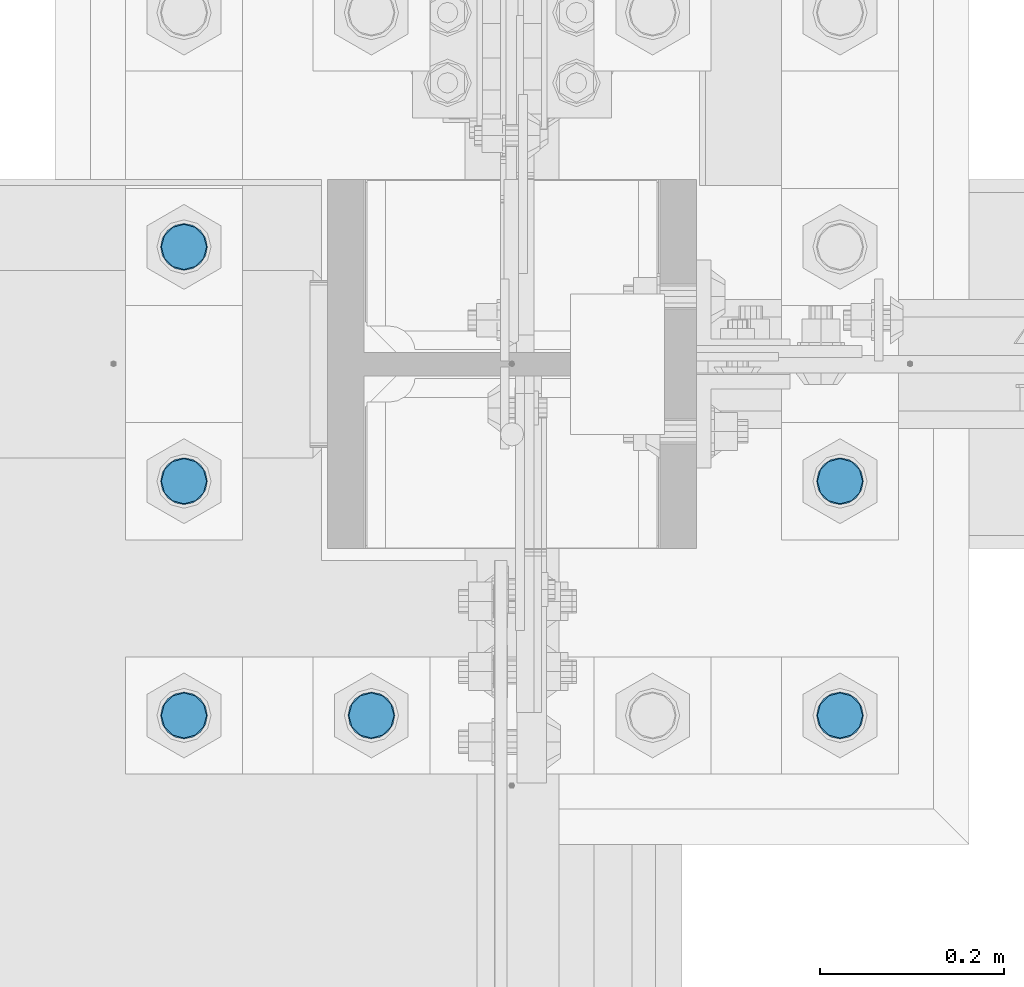
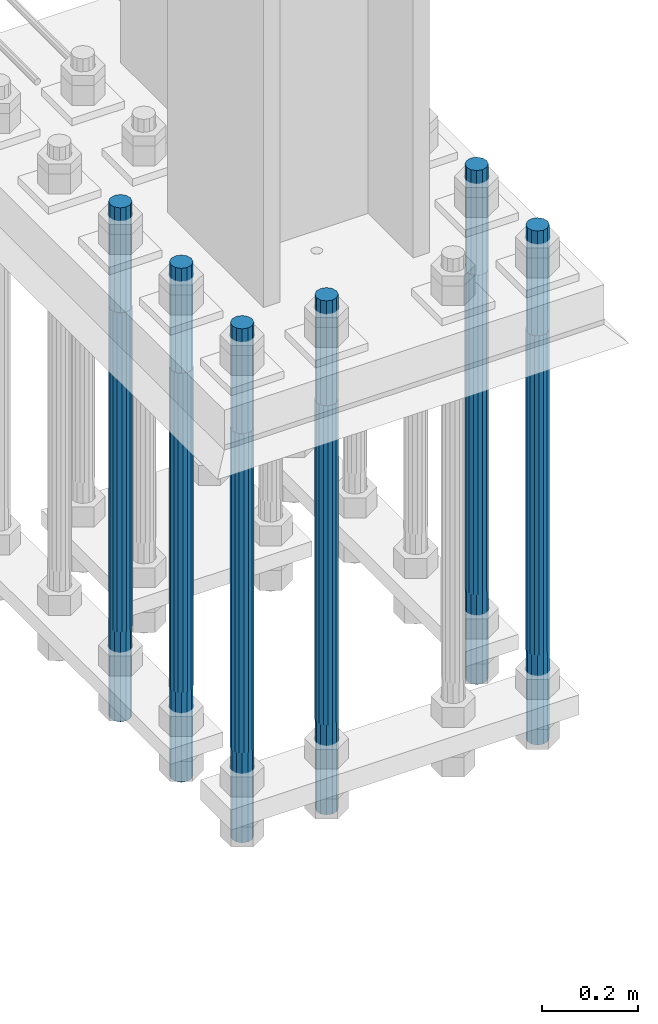
# One storey, part 1326 of 3843: 6 columns, 1 element without a shape of its own.
"""IFC2X3 building model written with IfcOpenShell, lengths in millimetres."""

from ifc_helpers import new_model, si_unit, frame, origin_with_axes, place, context, subcontext, project, spatial, faceted_brep, material, type_object, element, aggregate, save


model = new_model("IFC2X3")

# Units and contexts
model_context = context("Model", 3, precision=1e-05, world=origin_with_axes())
body_context = subcontext(model_context, "Body", "Model", "MODEL_VIEW")
ifc_project = project(units=[si_unit("LENGTHUNIT", "METRE", prefix="MILLI"), si_unit("AREAUNIT", "SQUARE_METRE"), si_unit("VOLUMEUNIT", "CUBIC_METRE"), si_unit("MASSUNIT", "GRAM", prefix="KILO"), si_unit("TIMEUNIT", "SECOND"), si_unit("PLANEANGLEUNIT", "RADIAN"), si_unit("SOLIDANGLEUNIT", "STERADIAN"), si_unit("THERMODYNAMICTEMPERATUREUNIT", "DEGREE_CELSIUS"), si_unit("LUMINOUSINTENSITYUNIT", "LUMEN")], contexts=[model_context])

# Site, building, storey
site_placement = place(None, origin_with_axes())
site = spatial("IfcSite", under=ifc_project, at=site_placement, CompositionType="ELEMENT")
building_placement = place(site_placement, origin_with_axes())
building = spatial("IfcBuilding", under=site, at=building_placement, Name="Undefined", CompositionType="ELEMENT")
storey_placement = place(building_placement, origin_with_axes())
storey = spatial("IfcBuildingStorey", under=building, at=storey_placement, Name="Undefined", CompositionType="ELEMENT", Elevation=0.0)

# Assembly, columns
assembly_placement = place(storey_placement, origin_with_axes())
assembly = element("IfcElementAssembly", 1, at=assembly_placement, inside=storey, Name="TEMPLATE", AssemblyPlace="NOTDEFINED", PredefinedType="RIGID_FRAME")
ifc_material = material(Name="Undefined/F1554-GR.55")
column_type = type_object("IfcColumnType", PredefinedType="NOTDEFINED")
column_1_placement = place(assembly_placement, frame((36931.6, 50177.7, 30022.8), z_axis=(1.0, 0.0, 0.0), x_axis=(0.0, 0.0, -1.0)))
column_1 = element("IfcColumn", 2, at=column_1_placement, type_object=column_type, material=ifc_material, Name="ANCHOR_ROD", context=body_context, shape_type="Brep", body=[
    faceted_brep([(-266.700000000001, -21.2176223927236, 12.25), (-266.700000000001, -12.25, 21.2176223927163), (-266.700000000001, 0.0, 24.5), (-266.700000000001, 12.25, 21.2176223927163), (-266.700000000001, 21.2176223927236, 12.25), (-266.700000000001, 24.5, 0.0), (-266.700000000001, 21.2176223927236, -12.25), (-266.700000000001, 12.25, -21.2176223927163), (-266.700000000001, 0.0, -24.5), (-266.700000000001, -12.25, -21.2176223927163), (-266.700000000001, -21.2176223927236, -12.25), (-266.700000000001, -24.5, 0.0), (0.0, 24.5000000000146, 0.0), (0.0, 21.2176223927381, -12.25), (0.0, 12.2500000000146, -21.2176223927163), (0.0, 1.45519152283669e-11, -24.5), (0.0, -12.2499999999854, -21.2176223927163), (0.0, -21.217622392709, -12.25), (0.0, -24.4999999999854, 0.0), (0.0, -21.217622392709, 12.25), (0.0, -12.2499999999854, 21.2176223927163), (0.0, 1.45519152283669e-11, 24.5), (0.0, 12.2500000000146, 21.2176223927163), (0.0, 21.2176223927381, 12.25), (0.0, -23.4665401257807, 9.72015918207035), (0.0, -17.9605122421344, 17.9605122421417), (0.0, -9.72015918207762, 23.466540125788), (0.0, 0.0, 25.4000000000015), (0.0, 9.72015918207762, 23.466540125788), (0.0, 17.9605122421344, 17.9605122421417), (0.0, 23.4665401257807, 9.72015918207035), (0.0, 25.3999996185303, 0.0), (0.0, 23.4665401257807, -9.72015918207035), (0.0, 17.9605122421344, -17.9605122421417), (0.0, 9.72015918207762, -23.466540125788), (0.0, 0.0, -25.4000000000015), (0.0, -9.72015918207762, -23.466540125788), (0.0, -17.9605122421344, -17.9605122421417), (0.0, -23.4665401257807, -9.72015918207035), (0.0, -25.3999996185303, 0.0), (812.799999999999, -25.4000000000015, 0.0), (812.799999999999, -23.466540125788, 9.72015918207398), (812.799999999999, -17.9605122421417, 17.9605122421381), (812.799999999999, -9.72015918207035, 23.466540125788), (812.799999999999, 0.0, 25.4000000000015), (812.799999999999, 9.72015918207035, 23.466540125788), (812.799999999999, 17.9605122421417, 17.9605122421381), (812.799999999999, 23.466540125788, 9.72015918207398), (812.799999999999, 25.4000000000015, 0.0), (812.799999999999, 23.466540125788, -9.72015918207398), (812.799999999999, 17.9605122421417, -17.9605122421381), (812.799999999999, 9.72015918207035, -23.466540125788), (812.799999999999, 0.0, -25.4000000000015), (812.799999999999, -9.72015918207035, -23.466540125788), (812.799999999999, -17.9605122421417, -17.9605122421381), (812.799999999999, -23.466540125788, -9.72015918207398), (812.799999999999, -12.25, 21.2176223927199), (812.799999999999, 0.0, 24.5), (812.799999999999, 12.25, 21.2176223927199), (812.799999999999, 21.2176223927163, 12.25), (812.799999999999, 24.5, 0.0), (812.799999999999, 21.2176223927163, -12.25), (812.799999999999, 12.25, -21.2176223927199), (812.799999999999, 0.0, -24.5), (812.799999999999, -12.25, -21.2176223927199), (812.799999999999, -21.2176223927163, -12.25), (812.799999999999, -24.5, 0.0), (812.799999999999, -21.2176223927163, 12.25), (1041.4, -12.25, -21.2176223927199), (1041.4, 0.0, -24.5), (1041.4, 12.25, -21.2176223927199), (1041.4, 21.2176223927163, -12.25), (1041.4, 24.5, 0.0), (1041.4, 21.2176223927163, 12.25), (1041.4, 12.25, 21.2176223927199), (1041.4, 0.0, 24.5), (1041.4, -12.25, 21.2176223927199), (1041.4, -21.2176223927163, 12.25), (1041.4, -24.5, 0.0), (1041.4, -21.2176223927163, -12.25)], [[[0, 1, 2, 3, 4, 5, 6, 7, 8, 9, 10, 11]], [[6, 5, 12, 13]], [[7, 6, 13, 14]], [[8, 7, 14, 15]], [[9, 8, 15, 16]], [[10, 9, 16, 17]], [[11, 10, 17, 18]], [[0, 11, 18, 19]], [[1, 0, 19, 20]], [[2, 1, 20, 21]], [[3, 2, 21, 22]], [[4, 3, 22, 23]], [[5, 4, 23, 12]], [[24, 25, 26, 27, 28, 29, 30, 31, 32, 33, 34, 35, 36, 37, 38, 39], [22, 21, 20, 19, 18, 17, 16, 15, 14, 13, 12, 23]], [[24, 39, 40, 41]], [[25, 24, 41, 42]], [[26, 25, 42, 43]], [[27, 26, 43, 44]], [[28, 27, 44, 45]], [[29, 28, 45, 46]], [[30, 29, 46, 47]], [[31, 30, 47, 48]], [[32, 31, 48, 49]], [[33, 32, 49, 50]], [[34, 33, 50, 51]], [[35, 34, 51, 52]], [[36, 35, 52, 53]], [[37, 36, 53, 54]], [[38, 37, 54, 55]], [[39, 38, 55, 40]], [[54, 53, 52, 51, 50, 49, 48, 47, 46, 45, 44, 43, 42, 41, 40, 55], [56, 57, 58, 59, 60, 61, 62, 63, 64, 65, 66, 67]], [[68, 69, 70, 71, 72, 73, 74, 75, 76, 77, 78, 79]], [[76, 75, 57, 56]], [[77, 76, 56, 67]], [[78, 77, 67, 66]], [[79, 78, 66, 65]], [[68, 79, 65, 64]], [[69, 68, 64, 63]], [[70, 69, 63, 62]], [[71, 70, 62, 61]], [[72, 71, 61, 60]], [[73, 72, 60, 59]], [[74, 73, 59, 58]], [[75, 74, 58, 57]]]),
])
column_2_placement = place(assembly_placement, frame((36931.6, 50431.7, 30022.8), z_axis=(1.0, 0.0, 0.0), x_axis=(0.0, 0.0, -1.0)))
column_2 = element("IfcColumn", 3, at=column_2_placement, type_object=column_type, material=ifc_material, Name="ANCHOR_ROD", context=body_context, shape_type="Brep", body=[
    faceted_brep([(-266.700000000001, -21.2176223927236, 12.25), (-266.700000000001, -12.25, 21.2176223927163), (-266.700000000001, 0.0, 24.5), (-266.700000000001, 12.25, 21.2176223927163), (-266.700000000001, 21.2176223927236, 12.25), (-266.700000000001, 24.5, 0.0), (-266.700000000001, 21.2176223927236, -12.25), (-266.700000000001, 12.25, -21.2176223927163), (-266.700000000001, 0.0, -24.5), (-266.700000000001, -12.25, -21.2176223927163), (-266.700000000001, -21.2176223927236, -12.25), (-266.700000000001, -24.5, 0.0), (0.0, 24.5000000000146, 0.0), (0.0, 21.2176223927381, -12.25), (0.0, 12.2500000000146, -21.2176223927163), (0.0, 1.45519152283669e-11, -24.5), (0.0, -12.2499999999854, -21.2176223927163), (0.0, -21.217622392709, -12.25), (0.0, -24.4999999999854, 0.0), (0.0, -21.217622392709, 12.25), (0.0, -12.2499999999854, 21.2176223927163), (0.0, 1.45519152283669e-11, 24.5), (0.0, 12.2500000000146, 21.2176223927163), (0.0, 21.2176223927381, 12.25), (0.0, -23.4665401257807, 9.72015918207035), (0.0, -17.9605122421344, 17.9605122421417), (0.0, -9.72015918207762, 23.466540125788), (0.0, 0.0, 25.4000000000015), (0.0, 9.72015918207762, 23.466540125788), (0.0, 17.9605122421344, 17.9605122421417), (0.0, 23.4665401257807, 9.72015918207035), (0.0, 25.3999996185303, 0.0), (0.0, 23.4665401257807, -9.72015918207035), (0.0, 17.9605122421344, -17.9605122421417), (0.0, 9.72015918207762, -23.466540125788), (0.0, 0.0, -25.4000000000015), (0.0, -9.72015918207762, -23.466540125788), (0.0, -17.9605122421344, -17.9605122421417), (0.0, -23.4665401257807, -9.72015918207035), (0.0, -25.3999996185303, 0.0), (812.799999999999, -25.4000000000015, 0.0), (812.799999999999, -23.466540125788, 9.72015918207398), (812.799999999999, -17.9605122421417, 17.9605122421381), (812.799999999999, -9.72015918207035, 23.466540125788), (812.799999999999, 0.0, 25.4000000000015), (812.799999999999, 9.72015918207035, 23.466540125788), (812.799999999999, 17.9605122421417, 17.9605122421381), (812.799999999999, 23.466540125788, 9.72015918207398), (812.799999999999, 25.4000000000015, 0.0), (812.799999999999, 23.466540125788, -9.72015918207398), (812.799999999999, 17.9605122421417, -17.9605122421381), (812.799999999999, 9.72015918207035, -23.466540125788), (812.799999999999, 0.0, -25.4000000000015), (812.799999999999, -9.72015918207035, -23.466540125788), (812.799999999999, -17.9605122421417, -17.9605122421381), (812.799999999999, -23.466540125788, -9.72015918207398), (812.799999999999, -12.25, 21.2176223927199), (812.799999999999, 0.0, 24.5), (812.799999999999, 12.25, 21.2176223927199), (812.799999999999, 21.2176223927163, 12.25), (812.799999999999, 24.5, 0.0), (812.799999999999, 21.2176223927163, -12.25), (812.799999999999, 12.25, -21.2176223927199), (812.799999999999, 0.0, -24.5), (812.799999999999, -12.25, -21.2176223927199), (812.799999999999, -21.2176223927163, -12.25), (812.799999999999, -24.5, 0.0), (812.799999999999, -21.2176223927163, 12.25), (1041.4, -12.25, -21.2176223927199), (1041.4, 0.0, -24.5), (1041.4, 12.25, -21.2176223927199), (1041.4, 21.2176223927163, -12.25), (1041.4, 24.5, 0.0), (1041.4, 21.2176223927163, 12.25), (1041.4, 12.25, 21.2176223927199), (1041.4, 0.0, 24.5), (1041.4, -12.25, 21.2176223927199), (1041.4, -21.2176223927163, 12.25), (1041.4, -24.5, 0.0), (1041.4, -21.2176223927163, -12.25)], [[[0, 1, 2, 3, 4, 5, 6, 7, 8, 9, 10, 11]], [[6, 5, 12, 13]], [[7, 6, 13, 14]], [[8, 7, 14, 15]], [[9, 8, 15, 16]], [[10, 9, 16, 17]], [[11, 10, 17, 18]], [[0, 11, 18, 19]], [[1, 0, 19, 20]], [[2, 1, 20, 21]], [[3, 2, 21, 22]], [[4, 3, 22, 23]], [[5, 4, 23, 12]], [[24, 25, 26, 27, 28, 29, 30, 31, 32, 33, 34, 35, 36, 37, 38, 39], [22, 21, 20, 19, 18, 17, 16, 15, 14, 13, 12, 23]], [[24, 39, 40, 41]], [[25, 24, 41, 42]], [[26, 25, 42, 43]], [[27, 26, 43, 44]], [[28, 27, 44, 45]], [[29, 28, 45, 46]], [[30, 29, 46, 47]], [[31, 30, 47, 48]], [[32, 31, 48, 49]], [[33, 32, 49, 50]], [[34, 33, 50, 51]], [[35, 34, 51, 52]], [[36, 35, 52, 53]], [[37, 36, 53, 54]], [[38, 37, 54, 55]], [[39, 38, 55, 40]], [[54, 53, 52, 51, 50, 49, 48, 47, 46, 45, 44, 43, 42, 41, 40, 55], [56, 57, 58, 59, 60, 61, 62, 63, 64, 65, 66, 67]], [[68, 69, 70, 71, 72, 73, 74, 75, 76, 77, 78, 79]], [[76, 75, 57, 56]], [[77, 76, 56, 67]], [[78, 77, 67, 66]], [[79, 78, 66, 65]], [[68, 79, 65, 64]], [[69, 68, 64, 63]], [[70, 69, 63, 62]], [[71, 70, 62, 61]], [[72, 71, 61, 60]], [[73, 72, 60, 59]], [[74, 73, 59, 58]], [[75, 74, 58, 57]]]),
])
column_3_placement = place(assembly_placement, frame((36423.6, 50177.7, 30022.8), z_axis=(1.0, 0.0, 0.0), x_axis=(0.0, 0.0, -1.0)))
column_3 = element("IfcColumn", 4, at=column_3_placement, type_object=column_type, material=ifc_material, Name="ANCHOR_ROD", context=body_context, shape_type="Brep", body=[
    faceted_brep([(-266.700000000001, -21.2176223927236, 12.25), (-266.700000000001, -12.25, 21.2176223927163), (-266.700000000001, 0.0, 24.5), (-266.700000000001, 12.25, 21.2176223927163), (-266.700000000001, 21.2176223927236, 12.25), (-266.700000000001, 24.5, 0.0), (-266.700000000001, 21.2176223927236, -12.25), (-266.700000000001, 12.25, -21.2176223927163), (-266.700000000001, 0.0, -24.5), (-266.700000000001, -12.25, -21.2176223927163), (-266.700000000001, -21.2176223927236, -12.25), (-266.700000000001, -24.5, 0.0), (0.0, 24.5000000000146, 0.0), (0.0, 21.2176223927381, -12.25), (0.0, 12.2500000000146, -21.2176223927163), (0.0, 1.45519152283669e-11, -24.5), (0.0, -12.2499999999854, -21.2176223927163), (0.0, -21.217622392709, -12.25), (0.0, -24.4999999999854, 0.0), (0.0, -21.217622392709, 12.25), (0.0, -12.2499999999854, 21.2176223927163), (0.0, 1.45519152283669e-11, 24.5), (0.0, 12.2500000000146, 21.2176223927163), (0.0, 21.2176223927381, 12.25), (0.0, -23.4665401257807, 9.72015918207035), (0.0, -17.9605122421344, 17.9605122421417), (0.0, -9.72015918207762, 23.466540125788), (0.0, 0.0, 25.4000000000015), (0.0, 9.72015918207762, 23.466540125788), (0.0, 17.9605122421344, 17.9605122421417), (0.0, 23.4665401257807, 9.72015918207035), (0.0, 25.3999996185303, 0.0), (0.0, 23.4665401257807, -9.72015918207035), (0.0, 17.9605122421344, -17.9605122421417), (0.0, 9.72015918207762, -23.466540125788), (0.0, 0.0, -25.4000000000015), (0.0, -9.72015918207762, -23.466540125788), (0.0, -17.9605122421344, -17.9605122421417), (0.0, -23.4665401257807, -9.72015918207035), (0.0, -25.3999996185303, 0.0), (812.799999999999, -25.4000000000015, 0.0), (812.799999999999, -23.466540125788, 9.72015918207398), (812.799999999999, -17.9605122421417, 17.9605122421381), (812.799999999999, -9.72015918207035, 23.466540125788), (812.799999999999, 0.0, 25.4000000000015), (812.799999999999, 9.72015918207035, 23.466540125788), (812.799999999999, 17.9605122421417, 17.9605122421381), (812.799999999999, 23.466540125788, 9.72015918207398), (812.799999999999, 25.4000000000015, 0.0), (812.799999999999, 23.466540125788, -9.72015918207398), (812.799999999999, 17.9605122421417, -17.9605122421381), (812.799999999999, 9.72015918207035, -23.466540125788), (812.799999999999, 0.0, -25.4000000000015), (812.799999999999, -9.72015918207035, -23.466540125788), (812.799999999999, -17.9605122421417, -17.9605122421381), (812.799999999999, -23.466540125788, -9.72015918207398), (812.799999999999, -12.25, 21.2176223927199), (812.799999999999, 0.0, 24.5), (812.799999999999, 12.25, 21.2176223927199), (812.799999999999, 21.2176223927163, 12.25), (812.799999999999, 24.5, 0.0), (812.799999999999, 21.2176223927163, -12.25), (812.799999999999, 12.25, -21.2176223927199), (812.799999999999, 0.0, -24.5), (812.799999999999, -12.25, -21.2176223927199), (812.799999999999, -21.2176223927163, -12.25), (812.799999999999, -24.5, 0.0), (812.799999999999, -21.2176223927163, 12.25), (1041.4, -12.25, -21.2176223927199), (1041.4, 0.0, -24.5), (1041.4, 12.25, -21.2176223927199), (1041.4, 21.2176223927163, -12.25), (1041.4, 24.5, 0.0), (1041.4, 21.2176223927163, 12.25), (1041.4, 12.25, 21.2176223927199), (1041.4, 0.0, 24.5), (1041.4, -12.25, 21.2176223927199), (1041.4, -21.2176223927163, 12.25), (1041.4, -24.5, 0.0), (1041.4, -21.2176223927163, -12.25)], [[[0, 1, 2, 3, 4, 5, 6, 7, 8, 9, 10, 11]], [[6, 5, 12, 13]], [[7, 6, 13, 14]], [[8, 7, 14, 15]], [[9, 8, 15, 16]], [[10, 9, 16, 17]], [[11, 10, 17, 18]], [[0, 11, 18, 19]], [[1, 0, 19, 20]], [[2, 1, 20, 21]], [[3, 2, 21, 22]], [[4, 3, 22, 23]], [[5, 4, 23, 12]], [[24, 25, 26, 27, 28, 29, 30, 31, 32, 33, 34, 35, 36, 37, 38, 39], [22, 21, 20, 19, 18, 17, 16, 15, 14, 13, 12, 23]], [[24, 39, 40, 41]], [[25, 24, 41, 42]], [[26, 25, 42, 43]], [[27, 26, 43, 44]], [[28, 27, 44, 45]], [[29, 28, 45, 46]], [[30, 29, 46, 47]], [[31, 30, 47, 48]], [[32, 31, 48, 49]], [[33, 32, 49, 50]], [[34, 33, 50, 51]], [[35, 34, 51, 52]], [[36, 35, 52, 53]], [[37, 36, 53, 54]], [[38, 37, 54, 55]], [[39, 38, 55, 40]], [[54, 53, 52, 51, 50, 49, 48, 47, 46, 45, 44, 43, 42, 41, 40, 55], [56, 57, 58, 59, 60, 61, 62, 63, 64, 65, 66, 67]], [[68, 69, 70, 71, 72, 73, 74, 75, 76, 77, 78, 79]], [[76, 75, 57, 56]], [[77, 76, 56, 67]], [[78, 77, 67, 66]], [[79, 78, 66, 65]], [[68, 79, 65, 64]], [[69, 68, 64, 63]], [[70, 69, 63, 62]], [[71, 70, 62, 61]], [[72, 71, 61, 60]], [[73, 72, 60, 59]], [[74, 73, 59, 58]], [[75, 74, 58, 57]]]),
])
column_4_placement = place(assembly_placement, frame((36220.4, 50177.7, 30022.8), z_axis=(1.0, 0.0, 0.0), x_axis=(0.0, 0.0, -1.0)))
column_4 = element("IfcColumn", 5, at=column_4_placement, type_object=column_type, material=ifc_material, Name="ANCHOR_ROD", context=body_context, shape_type="Brep", body=[
    faceted_brep([(-266.700000000001, -21.2176223927236, 12.25), (-266.700000000001, -12.25, 21.2176223927163), (-266.700000000001, 0.0, 24.5), (-266.700000000001, 12.25, 21.2176223927163), (-266.700000000001, 21.2176223927236, 12.25), (-266.700000000001, 24.5, 0.0), (-266.700000000001, 21.2176223927236, -12.25), (-266.700000000001, 12.25, -21.2176223927163), (-266.700000000001, 0.0, -24.5), (-266.700000000001, -12.25, -21.2176223927163), (-266.700000000001, -21.2176223927236, -12.25), (-266.700000000001, -24.5, 0.0), (0.0, 24.5000000000146, 0.0), (0.0, 21.2176223927381, -12.25), (0.0, 12.2500000000146, -21.2176223927163), (0.0, 1.45519152283669e-11, -24.5), (0.0, -12.2499999999854, -21.2176223927163), (0.0, -21.217622392709, -12.25), (0.0, -24.4999999999854, 0.0), (0.0, -21.217622392709, 12.25), (0.0, -12.2499999999854, 21.2176223927163), (0.0, 1.45519152283669e-11, 24.5), (0.0, 12.2500000000146, 21.2176223927163), (0.0, 21.2176223927381, 12.25), (0.0, -23.4665401257807, 9.72015918207035), (0.0, -17.9605122421344, 17.9605122421417), (0.0, -9.72015918207762, 23.466540125788), (0.0, 0.0, 25.4000000000015), (0.0, 9.72015918207762, 23.466540125788), (0.0, 17.9605122421344, 17.9605122421417), (0.0, 23.4665401257807, 9.72015918207035), (0.0, 25.3999996185303, 0.0), (0.0, 23.4665401257807, -9.72015918207035), (0.0, 17.9605122421344, -17.9605122421417), (0.0, 9.72015918207762, -23.466540125788), (0.0, 0.0, -25.4000000000015), (0.0, -9.72015918207762, -23.466540125788), (0.0, -17.9605122421344, -17.9605122421417), (0.0, -23.4665401257807, -9.72015918207035), (0.0, -25.3999996185303, 0.0), (812.799999999999, -25.4000000000015, 0.0), (812.799999999999, -23.466540125788, 9.72015918207398), (812.799999999999, -17.9605122421417, 17.9605122421381), (812.799999999999, -9.72015918207035, 23.466540125788), (812.799999999999, 0.0, 25.4000000000015), (812.799999999999, 9.72015918207035, 23.466540125788), (812.799999999999, 17.9605122421417, 17.9605122421381), (812.799999999999, 23.466540125788, 9.72015918207398), (812.799999999999, 25.4000000000015, 0.0), (812.799999999999, 23.466540125788, -9.72015918207398), (812.799999999999, 17.9605122421417, -17.9605122421381), (812.799999999999, 9.72015918207035, -23.466540125788), (812.799999999999, 0.0, -25.4000000000015), (812.799999999999, -9.72015918207035, -23.466540125788), (812.799999999999, -17.9605122421417, -17.9605122421381), (812.799999999999, -23.466540125788, -9.72015918207398), (812.799999999999, -12.25, 21.2176223927199), (812.799999999999, 0.0, 24.5), (812.799999999999, 12.25, 21.2176223927199), (812.799999999999, 21.2176223927163, 12.25), (812.799999999999, 24.5, 0.0), (812.799999999999, 21.2176223927163, -12.25), (812.799999999999, 12.25, -21.2176223927199), (812.799999999999, 0.0, -24.5), (812.799999999999, -12.25, -21.2176223927199), (812.799999999999, -21.2176223927163, -12.25), (812.799999999999, -24.5, 0.0), (812.799999999999, -21.2176223927163, 12.25), (1041.4, -12.25, -21.2176223927199), (1041.4, 0.0, -24.5), (1041.4, 12.25, -21.2176223927199), (1041.4, 21.2176223927163, -12.25), (1041.4, 24.5, 0.0), (1041.4, 21.2176223927163, 12.25), (1041.4, 12.25, 21.2176223927199), (1041.4, 0.0, 24.5), (1041.4, -12.25, 21.2176223927199), (1041.4, -21.2176223927163, 12.25), (1041.4, -24.5, 0.0), (1041.4, -21.2176223927163, -12.25)], [[[0, 1, 2, 3, 4, 5, 6, 7, 8, 9, 10, 11]], [[6, 5, 12, 13]], [[7, 6, 13, 14]], [[8, 7, 14, 15]], [[9, 8, 15, 16]], [[10, 9, 16, 17]], [[11, 10, 17, 18]], [[0, 11, 18, 19]], [[1, 0, 19, 20]], [[2, 1, 20, 21]], [[3, 2, 21, 22]], [[4, 3, 22, 23]], [[5, 4, 23, 12]], [[24, 25, 26, 27, 28, 29, 30, 31, 32, 33, 34, 35, 36, 37, 38, 39], [22, 21, 20, 19, 18, 17, 16, 15, 14, 13, 12, 23]], [[24, 39, 40, 41]], [[25, 24, 41, 42]], [[26, 25, 42, 43]], [[27, 26, 43, 44]], [[28, 27, 44, 45]], [[29, 28, 45, 46]], [[30, 29, 46, 47]], [[31, 30, 47, 48]], [[32, 31, 48, 49]], [[33, 32, 49, 50]], [[34, 33, 50, 51]], [[35, 34, 51, 52]], [[36, 35, 52, 53]], [[37, 36, 53, 54]], [[38, 37, 54, 55]], [[39, 38, 55, 40]], [[54, 53, 52, 51, 50, 49, 48, 47, 46, 45, 44, 43, 42, 41, 40, 55], [56, 57, 58, 59, 60, 61, 62, 63, 64, 65, 66, 67]], [[68, 69, 70, 71, 72, 73, 74, 75, 76, 77, 78, 79]], [[76, 75, 57, 56]], [[77, 76, 56, 67]], [[78, 77, 67, 66]], [[79, 78, 66, 65]], [[68, 79, 65, 64]], [[69, 68, 64, 63]], [[70, 69, 63, 62]], [[71, 70, 62, 61]], [[72, 71, 61, 60]], [[73, 72, 60, 59]], [[74, 73, 59, 58]], [[75, 74, 58, 57]]]),
])
column_5_placement = place(assembly_placement, frame((36220.4, 50431.7, 30022.8), z_axis=(1.0, 0.0, 0.0), x_axis=(0.0, 0.0, -1.0)))
column_5 = element("IfcColumn", 6, at=column_5_placement, type_object=column_type, material=ifc_material, Name="ANCHOR_ROD", context=body_context, shape_type="Brep", body=[
    faceted_brep([(-266.700000000001, -21.2176223927236, 12.25), (-266.700000000001, -12.25, 21.2176223927163), (-266.700000000001, 0.0, 24.5), (-266.700000000001, 12.25, 21.2176223927163), (-266.700000000001, 21.2176223927236, 12.25), (-266.700000000001, 24.5, 0.0), (-266.700000000001, 21.2176223927236, -12.25), (-266.700000000001, 12.25, -21.2176223927163), (-266.700000000001, 0.0, -24.5), (-266.700000000001, -12.25, -21.2176223927163), (-266.700000000001, -21.2176223927236, -12.25), (-266.700000000001, -24.5, 0.0), (0.0, 24.5000000000146, 0.0), (0.0, 21.2176223927381, -12.25), (0.0, 12.2500000000146, -21.2176223927163), (0.0, 1.45519152283669e-11, -24.5), (0.0, -12.2499999999854, -21.2176223927163), (0.0, -21.217622392709, -12.25), (0.0, -24.4999999999854, 0.0), (0.0, -21.217622392709, 12.25), (0.0, -12.2499999999854, 21.2176223927163), (0.0, 1.45519152283669e-11, 24.5), (0.0, 12.2500000000146, 21.2176223927163), (0.0, 21.2176223927381, 12.25), (0.0, -23.4665401257807, 9.72015918207035), (0.0, -17.9605122421344, 17.9605122421417), (0.0, -9.72015918207762, 23.466540125788), (0.0, 0.0, 25.4000000000015), (0.0, 9.72015918207762, 23.466540125788), (0.0, 17.9605122421344, 17.9605122421417), (0.0, 23.4665401257807, 9.72015918207035), (0.0, 25.3999996185303, 0.0), (0.0, 23.4665401257807, -9.72015918207035), (0.0, 17.9605122421344, -17.9605122421417), (0.0, 9.72015918207762, -23.466540125788), (0.0, 0.0, -25.4000000000015), (0.0, -9.72015918207762, -23.466540125788), (0.0, -17.9605122421344, -17.9605122421417), (0.0, -23.4665401257807, -9.72015918207035), (0.0, -25.3999996185303, 0.0), (812.799999999999, -25.4000000000015, 0.0), (812.799999999999, -23.466540125788, 9.72015918207398), (812.799999999999, -17.9605122421417, 17.9605122421381), (812.799999999999, -9.72015918207035, 23.466540125788), (812.799999999999, 0.0, 25.4000000000015), (812.799999999999, 9.72015918207035, 23.466540125788), (812.799999999999, 17.9605122421417, 17.9605122421381), (812.799999999999, 23.466540125788, 9.72015918207398), (812.799999999999, 25.4000000000015, 0.0), (812.799999999999, 23.466540125788, -9.72015918207398), (812.799999999999, 17.9605122421417, -17.9605122421381), (812.799999999999, 9.72015918207035, -23.466540125788), (812.799999999999, 0.0, -25.4000000000015), (812.799999999999, -9.72015918207035, -23.466540125788), (812.799999999999, -17.9605122421417, -17.9605122421381), (812.799999999999, -23.466540125788, -9.72015918207398), (812.799999999999, -12.25, 21.2176223927199), (812.799999999999, 0.0, 24.5), (812.799999999999, 12.25, 21.2176223927199), (812.799999999999, 21.2176223927163, 12.25), (812.799999999999, 24.5, 0.0), (812.799999999999, 21.2176223927163, -12.25), (812.799999999999, 12.25, -21.2176223927199), (812.799999999999, 0.0, -24.5), (812.799999999999, -12.25, -21.2176223927199), (812.799999999999, -21.2176223927163, -12.25), (812.799999999999, -24.5, 0.0), (812.799999999999, -21.2176223927163, 12.25), (1041.4, -12.25, -21.2176223927199), (1041.4, 0.0, -24.5), (1041.4, 12.25, -21.2176223927199), (1041.4, 21.2176223927163, -12.25), (1041.4, 24.5, 0.0), (1041.4, 21.2176223927163, 12.25), (1041.4, 12.25, 21.2176223927199), (1041.4, 0.0, 24.5), (1041.4, -12.25, 21.2176223927199), (1041.4, -21.2176223927163, 12.25), (1041.4, -24.5, 0.0), (1041.4, -21.2176223927163, -12.25)], [[[0, 1, 2, 3, 4, 5, 6, 7, 8, 9, 10, 11]], [[6, 5, 12, 13]], [[7, 6, 13, 14]], [[8, 7, 14, 15]], [[9, 8, 15, 16]], [[10, 9, 16, 17]], [[11, 10, 17, 18]], [[0, 11, 18, 19]], [[1, 0, 19, 20]], [[2, 1, 20, 21]], [[3, 2, 21, 22]], [[4, 3, 22, 23]], [[5, 4, 23, 12]], [[24, 25, 26, 27, 28, 29, 30, 31, 32, 33, 34, 35, 36, 37, 38, 39], [22, 21, 20, 19, 18, 17, 16, 15, 14, 13, 12, 23]], [[24, 39, 40, 41]], [[25, 24, 41, 42]], [[26, 25, 42, 43]], [[27, 26, 43, 44]], [[28, 27, 44, 45]], [[29, 28, 45, 46]], [[30, 29, 46, 47]], [[31, 30, 47, 48]], [[32, 31, 48, 49]], [[33, 32, 49, 50]], [[34, 33, 50, 51]], [[35, 34, 51, 52]], [[36, 35, 52, 53]], [[37, 36, 53, 54]], [[38, 37, 54, 55]], [[39, 38, 55, 40]], [[54, 53, 52, 51, 50, 49, 48, 47, 46, 45, 44, 43, 42, 41, 40, 55], [56, 57, 58, 59, 60, 61, 62, 63, 64, 65, 66, 67]], [[68, 69, 70, 71, 72, 73, 74, 75, 76, 77, 78, 79]], [[76, 75, 57, 56]], [[77, 76, 56, 67]], [[78, 77, 67, 66]], [[79, 78, 66, 65]], [[68, 79, 65, 64]], [[69, 68, 64, 63]], [[70, 69, 63, 62]], [[71, 70, 62, 61]], [[72, 71, 61, 60]], [[73, 72, 60, 59]], [[74, 73, 59, 58]], [[75, 74, 58, 57]]]),
])
column_6_placement = place(assembly_placement, frame((36220.4, 50685.7, 30022.8), z_axis=(1.0, 0.0, 0.0), x_axis=(0.0, 0.0, -1.0)))
column_6 = element("IfcColumn", 7, at=column_6_placement, type_object=column_type, material=ifc_material, Name="ANCHOR_ROD", context=body_context, shape_type="Brep", body=[
    faceted_brep([(-266.700000000001, -21.2176223927236, 12.25), (-266.700000000001, -12.25, 21.2176223927163), (-266.700000000001, 0.0, 24.5), (-266.700000000001, 12.25, 21.2176223927163), (-266.700000000001, 21.2176223927236, 12.25), (-266.700000000001, 24.5, 0.0), (-266.700000000001, 21.2176223927236, -12.25), (-266.700000000001, 12.25, -21.2176223927163), (-266.700000000001, 0.0, -24.5), (-266.700000000001, -12.25, -21.2176223927163), (-266.700000000001, -21.2176223927236, -12.25), (-266.700000000001, -24.5, 0.0), (0.0, 24.5000000000146, 0.0), (0.0, 21.2176223927381, -12.25), (0.0, 12.2500000000146, -21.2176223927163), (0.0, 1.45519152283669e-11, -24.5), (0.0, -12.2499999999854, -21.2176223927163), (0.0, -21.217622392709, -12.25), (0.0, -24.4999999999854, 0.0), (0.0, -21.217622392709, 12.25), (0.0, -12.2499999999854, 21.2176223927163), (0.0, 1.45519152283669e-11, 24.5), (0.0, 12.2500000000146, 21.2176223927163), (0.0, 21.2176223927381, 12.25), (0.0, -23.4665401257807, 9.72015918207035), (0.0, -17.9605122421344, 17.9605122421417), (0.0, -9.72015918207762, 23.466540125788), (0.0, 0.0, 25.4000000000015), (0.0, 9.72015918207762, 23.466540125788), (0.0, 17.9605122421344, 17.9605122421417), (0.0, 23.4665401257807, 9.72015918207035), (0.0, 25.3999996185303, 0.0), (0.0, 23.4665401257807, -9.72015918207035), (0.0, 17.9605122421344, -17.9605122421417), (0.0, 9.72015918207762, -23.466540125788), (0.0, 0.0, -25.4000000000015), (0.0, -9.72015918207762, -23.466540125788), (0.0, -17.9605122421344, -17.9605122421417), (0.0, -23.4665401257807, -9.72015918207035), (0.0, -25.3999996185303, 0.0), (812.799999999999, -25.4000000000015, 0.0), (812.799999999999, -23.466540125788, 9.72015918207398), (812.799999999999, -17.9605122421417, 17.9605122421381), (812.799999999999, -9.72015918207035, 23.466540125788), (812.799999999999, 0.0, 25.4000000000015), (812.799999999999, 9.72015918207035, 23.466540125788), (812.799999999999, 17.9605122421417, 17.9605122421381), (812.799999999999, 23.466540125788, 9.72015918207398), (812.799999999999, 25.4000000000015, 0.0), (812.799999999999, 23.466540125788, -9.72015918207398), (812.799999999999, 17.9605122421417, -17.9605122421381), (812.799999999999, 9.72015918207035, -23.466540125788), (812.799999999999, 0.0, -25.4000000000015), (812.799999999999, -9.72015918207035, -23.466540125788), (812.799999999999, -17.9605122421417, -17.9605122421381), (812.799999999999, -23.466540125788, -9.72015918207398), (812.799999999999, -12.25, 21.2176223927199), (812.799999999999, 0.0, 24.5), (812.799999999999, 12.25, 21.2176223927199), (812.799999999999, 21.2176223927163, 12.25), (812.799999999999, 24.5, 0.0), (812.799999999999, 21.2176223927163, -12.25), (812.799999999999, 12.25, -21.2176223927199), (812.799999999999, 0.0, -24.5), (812.799999999999, -12.25, -21.2176223927199), (812.799999999999, -21.2176223927163, -12.25), (812.799999999999, -24.5, 0.0), (812.799999999999, -21.2176223927163, 12.25), (1041.4, -12.25, -21.2176223927199), (1041.4, 0.0, -24.5), (1041.4, 12.25, -21.2176223927199), (1041.4, 21.2176223927163, -12.25), (1041.4, 24.5, 0.0), (1041.4, 21.2176223927163, 12.25), (1041.4, 12.25, 21.2176223927199), (1041.4, 0.0, 24.5), (1041.4, -12.25, 21.2176223927199), (1041.4, -21.2176223927163, 12.25), (1041.4, -24.5, 0.0), (1041.4, -21.2176223927163, -12.25)], [[[0, 1, 2, 3, 4, 5, 6, 7, 8, 9, 10, 11]], [[6, 5, 12, 13]], [[7, 6, 13, 14]], [[8, 7, 14, 15]], [[9, 8, 15, 16]], [[10, 9, 16, 17]], [[11, 10, 17, 18]], [[0, 11, 18, 19]], [[1, 0, 19, 20]], [[2, 1, 20, 21]], [[3, 2, 21, 22]], [[4, 3, 22, 23]], [[5, 4, 23, 12]], [[24, 25, 26, 27, 28, 29, 30, 31, 32, 33, 34, 35, 36, 37, 38, 39], [22, 21, 20, 19, 18, 17, 16, 15, 14, 13, 12, 23]], [[24, 39, 40, 41]], [[25, 24, 41, 42]], [[26, 25, 42, 43]], [[27, 26, 43, 44]], [[28, 27, 44, 45]], [[29, 28, 45, 46]], [[30, 29, 46, 47]], [[31, 30, 47, 48]], [[32, 31, 48, 49]], [[33, 32, 49, 50]], [[34, 33, 50, 51]], [[35, 34, 51, 52]], [[36, 35, 52, 53]], [[37, 36, 53, 54]], [[38, 37, 54, 55]], [[39, 38, 55, 40]], [[54, 53, 52, 51, 50, 49, 48, 47, 46, 45, 44, 43, 42, 41, 40, 55], [56, 57, 58, 59, 60, 61, 62, 63, 64, 65, 66, 67]], [[68, 69, 70, 71, 72, 73, 74, 75, 76, 77, 78, 79]], [[76, 75, 57, 56]], [[77, 76, 56, 67]], [[78, 77, 67, 66]], [[79, 78, 66, 65]], [[68, 79, 65, 64]], [[69, 68, 64, 63]], [[70, 69, 63, 62]], [[71, 70, 62, 61]], [[72, 71, 61, 60]], [[73, 72, 60, 59]], [[74, 73, 59, 58]], [[75, 74, 58, 57]]]),
])
aggregate(assembly, [column_1, column_2, column_3, column_4, column_5, column_6])

save(model, "model.ifc")
